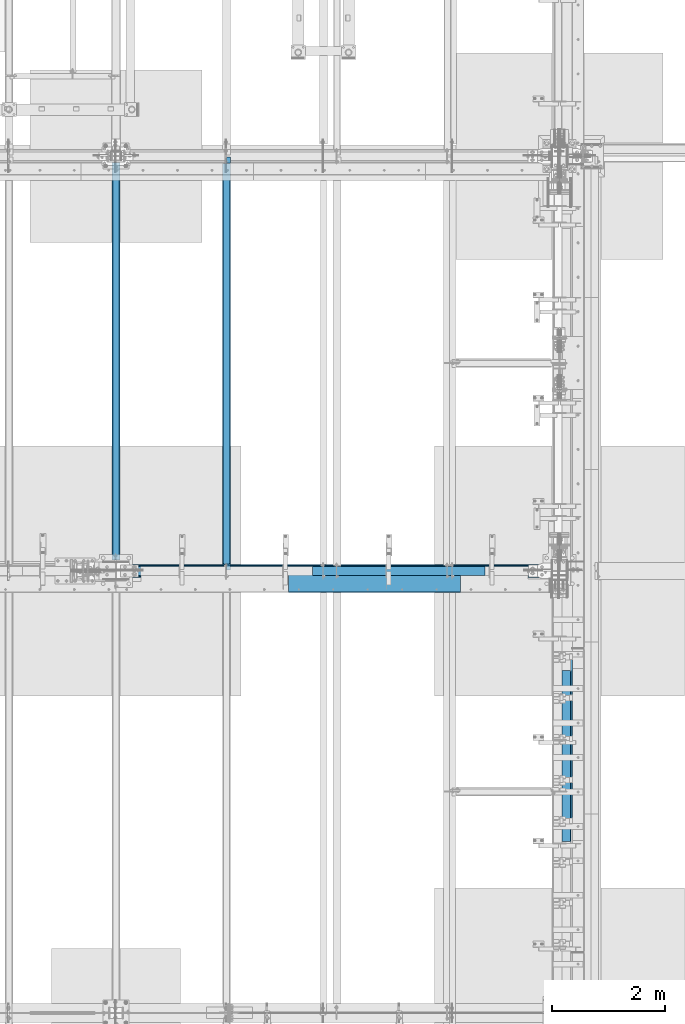
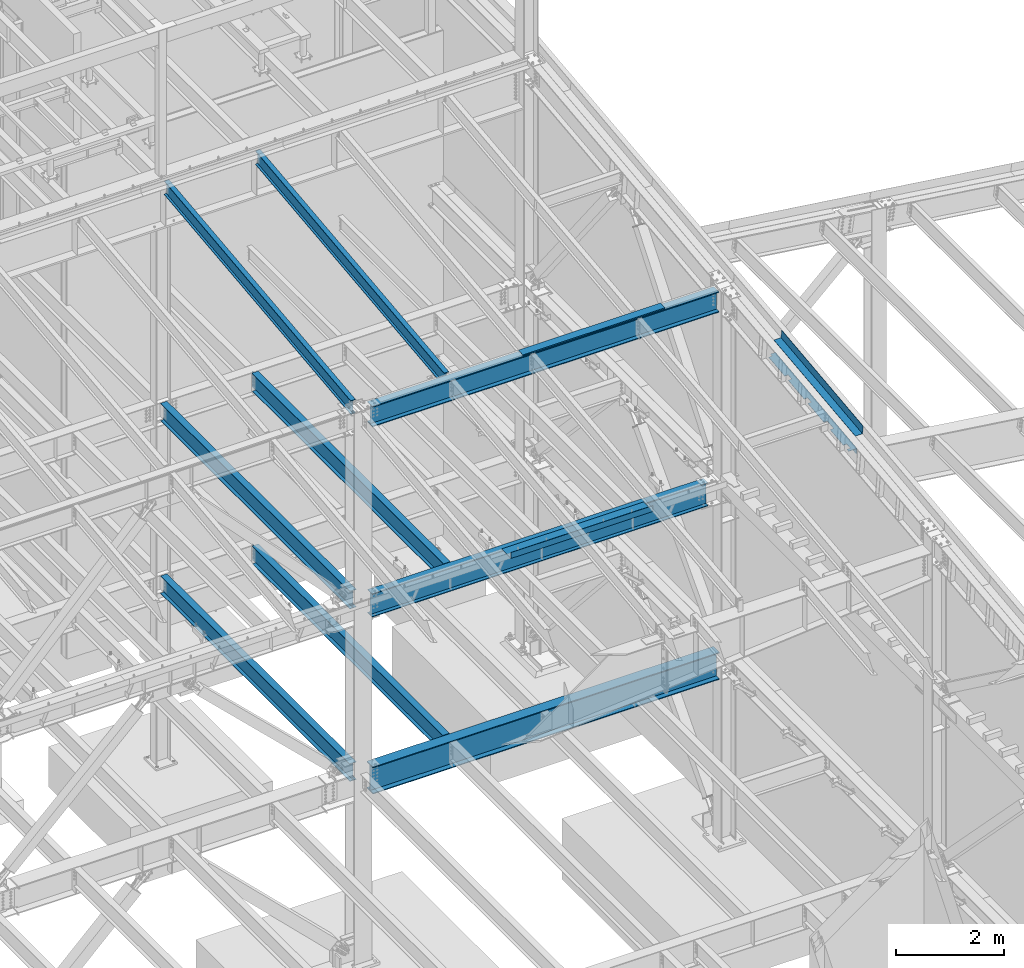
# One storey, part 739 of 1179: 13 beams, 10 elements without a shape of their own.
"""IFC2X3 building model written with IfcOpenShell, lengths in millimetres."""

from ifc_helpers import new_model, si_unit, frame, origin_with_axes, place, context, subcontext, project, spatial, faceted_brep, material, type_object, element, aggregate, save


model = new_model("IFC2X3")

# Units and contexts
model_context = context("Model", 3, precision=1e-05, world=origin_with_axes())
body_context = subcontext(model_context, "Body", "Model", "MODEL_VIEW")
ifc_project = project(units=[si_unit("LENGTHUNIT", "METRE", prefix="MILLI"), si_unit("AREAUNIT", "SQUARE_METRE"), si_unit("VOLUMEUNIT", "CUBIC_METRE"), si_unit("MASSUNIT", "GRAM", prefix="KILO"), si_unit("TIMEUNIT", "SECOND"), si_unit("PLANEANGLEUNIT", "RADIAN"), si_unit("SOLIDANGLEUNIT", "STERADIAN"), si_unit("THERMODYNAMICTEMPERATUREUNIT", "DEGREE_CELSIUS"), si_unit("LUMINOUSINTENSITYUNIT", "LUMEN")], contexts=[model_context])

# Site, building, storey
site_placement = place(None, origin_with_axes())
site = spatial("IfcSite", under=ifc_project, at=site_placement, CompositionType="ELEMENT")
building_placement = place(site_placement, origin_with_axes())
building = spatial("IfcBuilding", under=site, at=building_placement, Name="Undefined", CompositionType="ELEMENT")
storey_placement = place(building_placement, origin_with_axes())
storey = spatial("IfcBuildingStorey", under=building, at=storey_placement, Name="Undefined", CompositionType="ELEMENT", Elevation=0.0)

# Assembly, beam
assembly_1_placement = place(storey_placement, origin_with_axes())
assembly_1 = element("IfcElementAssembly", 1, at=assembly_1_placement, inside=storey, Name="BEAM", AssemblyPlace="NOTDEFINED", PredefinedType="RIGID_FRAME")
ifc_material_1 = material(Name="STEEL/A36")
beam_type_1 = type_object("IfcBeamType", PredefinedType="NOTDEFINED")
beam_1_placement = place(assembly_1_placement, frame((21463.0000078249, 27124.0249999701, 12269.3906249899), z_axis=(-1.0, 0.0, 0.0), x_axis=(0.0, 0.0, 1.0)))
beam_1 = element("IfcBeam", 2, at=beam_1_placement, type_object=beam_type_1, material=ifc_material_1, Name="BENT_PLATE", context=body_context, shape_type="Brep", body=[
    faceted_brep([(-2.91038304567337e-11, -4.76250000000073, -1524.0), (-2.91038304567337e-11, -4.76250000000073, 1524.0), (2.91038304567337e-11, 4.76250000000073, 1524.0), (2.91038304567337e-11, 4.76250000000073, -1524.0), (43.0065173285329, 4.76249999974607, 1524.0), (43.0065173285329, 4.76249999974607, -1524.0), (32.344586885798, -4.7625000001899, -1524.0), (32.344586885798, -4.7625000001899, 1524.0), (25.4267482213236, -150.812499999749, 1524.0), (25.4267482213236, -150.812499999749, -1524.0), (16.9174425672263, -141.287499999748, -1524.0), (16.9174425672263, -141.287499999748, 1524.0), (8.54161044117063e-08, -150.812499999749, 1524.0), (8.54161044117063e-08, -150.812499999749, -1524.0), (8.54161044117063e-08, -141.287499999748, 1524.0), (8.54161044117063e-08, -141.287499999748, -1524.0)], [[[0, 1, 2, 3]], [[3, 2, 4, 5]], [[1, 0, 6, 7]], [[5, 4, 8, 9]], [[7, 6, 10, 11]], [[9, 8, 12, 13]], [[8, 4, 2, 1, 7, 11, 14, 12]], [[11, 10, 15, 14]], [[10, 6, 0, 3, 5, 9, 13, 15]], [[14, 15, 13, 12]]]),
])

assembly_2_placement = place(storey_placement, origin_with_axes())
assembly_2 = element("IfcElementAssembly", 3, at=assembly_2_placement, inside=storey, Name="BEAM", AssemblyPlace="NOTDEFINED", PredefinedType="RIGID_FRAME")
ifc_material_2 = material(Name="STEEL/A992")
beam_type_2 = type_object("IfcBeamType", Name="W16X31", PredefinedType="NOTDEFINED")
beam_2_placement = place(assembly_2_placement, frame((18415.0, 27051.0, 7812.0875), z_axis=(0.0, 0.0, 1.0), x_axis=(0.0, 1.0, 0.0)))
beam_2 = element("IfcBeam", 4, at=beam_2_placement, type_object=beam_type_2, material=ifc_material_2, Name="BEAM", ObjectType="W16X31", context=body_context, shape_type="Brep", body=[
    faceted_brep([(82.5499999999993, -3.17500000000291, 166.6875), (82.5499999999993, 3.17500000000291, 166.6875), (17.4624999999942, 3.17499999999927, 166.6875), (17.4624999999942, -3.17499999999927, 166.6875), (87.4100797087813, -3.17499999999927, 167.654229922588), (87.4100797087813, 3.17497144083973, 167.654229922588), (91.5302561769349, -3.17499999999927, 170.407243823066), (91.5302561769349, 3.17496966460385, 170.407243823066), (94.2832700774125, -3.17499999999927, 174.52742029122), (94.2832700774125, 3.1749670062818, 174.52742029122), (95.25, -3.17499999999927, 179.387499809265), (95.25, 3.1749638705769, 179.387499809265), (95.25, -69.8499999999985, 201.6125), (95.25, 69.8499999999985, 201.6125), (95.25, 69.8499999999985, 190.5), (95.25, 3.17499999999927, 190.5), (95.25, -3.17499999999927, 190.5), (95.25, -69.8499999999985, 190.5), (7196.1375, 3.17499999999927, -190.5), (7196.1375, 69.8500000000004, -190.5), (144.462499999994, 69.8499999999985, -190.5), (144.462499999994, 3.17549991607666, -190.5), (17.4624999999942, -3.17499999999927, -190.5), (17.4624999999942, -69.8499999999985, -190.5), (7323.1375, -69.8500000000004, -190.5), (7323.1375, -3.17499999999927, -190.5), (17.4624999999942, -69.8499999999985, -201.6125), (7323.1375, -69.8500000000004, -201.6125), (7196.1375, 69.8500000000004, -201.6125), (7196.1375, 3.17549991607484, -201.6125), (7323.1375, 3.17549991607484, -201.6125), (17.4624999999942, 3.17549991607666, -201.6125), (144.462499999994, 3.17549991607666, -201.6125), (144.462499999994, 69.8499999999985, -201.6125), (17.4624999999942, 3.17499999999927, -190.5), (7323.1375, 3.17499999999927, -190.5), (7323.1375, 3.17499999999927, 166.6875), (7323.1375, -3.17499999999927, 166.6875), (7235.82499980928, 3.17499999999927, 166.6875), (7235.82499980928, -3.17499999999927, 166.6875), (7230.96492029123, 3.17499999999927, 167.654229922588), (7230.96492029123, -3.17499999999927, 167.654229922588), (7226.84474382308, 3.17499999999927, 170.407243823066), (7226.84474382308, -3.17499999999927, 170.407243823066), (7224.0917299226, 3.17499999999927, 174.52742029122), (7224.0917299226, -3.17499999999927, 174.52742029122), (7223.12500000001, 3.17499999999927, 179.387499809265), (7223.12500000001, -3.17499999999927, 179.387499809265), (7223.12500000001, -69.8500000000004, 201.6125), (7223.12500000001, -69.8500000000004, 190.5), (7223.12500000001, -3.17499999999927, 190.5), (7223.12500000001, 3.17499999999927, 190.5), (7223.12500000001, 69.8500000000004, 190.5), (7223.12500000001, 69.8500000000004, 201.6125)], [[[0, 1, 2, 3]], [[4, 5, 1, 0]], [[6, 7, 5, 4]], [[8, 9, 7, 6]], [[10, 11, 9, 8]], [[12, 13, 14, 15, 11, 10, 16, 17]], [[18, 19, 20, 21]], [[22, 23, 24, 25]], [[23, 26, 27, 24]], [[28, 29, 30, 27, 26, 31, 32, 33]], [[21, 32, 31, 34]], [[20, 33, 32, 21]], [[19, 28, 33, 20]], [[18, 29, 28, 19]], [[35, 30, 29, 18]], [[25, 24, 27, 30, 35, 36, 37]], [[37, 36, 38, 39]], [[39, 38, 40, 41]], [[41, 40, 42, 43]], [[43, 42, 44, 45]], [[45, 44, 46, 47]], [[48, 49, 50, 47, 46, 51, 52, 53]], [[49, 48, 12, 17]], [[50, 49, 17, 16]], [[8, 6, 4, 0, 3, 22, 25, 37, 39, 41, 43, 45, 47, 50, 16, 10]], [[34, 31, 26, 23, 22, 3, 2]], [[51, 46, 44, 42, 40, 38, 36, 35, 18, 21, 34, 2, 1, 5, 7, 9, 11, 15]], [[52, 51, 15, 14]], [[53, 52, 14, 13]], [[48, 53, 13, 12]]]),
])
aggregate(assembly_2, [beam_2])

assembly_3_placement = place(storey_placement, origin_with_axes())
assembly_3 = element("IfcElementAssembly", 5, at=assembly_3_placement, inside=storey, Name="BEAM", AssemblyPlace="NOTDEFINED", PredefinedType="RIGID_FRAME")
beam_3_placement = place(assembly_3_placement, frame((16459.2, 27051.0, 7812.0875), z_axis=(0.0, 0.0, 1.0), x_axis=(0.0, 1.0, 0.0)))
beam_3 = element("IfcBeam", 6, at=beam_3_placement, type_object=beam_type_2, material=ifc_material_2, Name="BEAM", ObjectType="W16X31", context=body_context, shape_type="Brep", body=[
    faceted_brep([(195.262500000001, -69.8499999999985, -201.6125), (195.262500000001, 69.8499999999985, -201.6125), (7224.7125, 69.8499999999985, -201.6125), (7224.7125, -69.8499999999985, -201.6125), (195.262500000001, -69.8499999999985, -190.5), (195.262500000001, -3.17499999999927, -190.5), (195.262500000001, -3.17499999999927, 190.5), (195.262500000001, -69.8499999999985, 190.5), (195.262500000001, -69.8499999999985, 201.6125), (195.262500000001, 69.8499999999985, 201.6125), (195.262500000001, 69.8499999999985, 190.5), (195.262500000001, 3.17499999999927, 190.5), (195.262500000001, 3.17499999999927, -190.5), (195.262500000001, 69.8499999999985, -190.5), (7224.7125, -69.8499999999985, -190.5), (7224.7125, -3.17499999999927, -190.5), (7224.7125, -3.17499999999927, 190.5), (7224.7125, -69.8499999999985, 190.5), (7224.7125, -69.8499999999985, 201.6125), (7224.7125, 69.8499999999985, 201.6125), (7224.7125, 69.8499999999985, 190.5), (7224.7125, 3.17499999999927, 190.5), (7224.7125, 3.17499999999927, 164.252489941818), (7224.7125, 3.17499999999927, -142.027503290603), (7224.7125, 3.17499999999927, -190.5), (7224.7125, 69.8499999999985, -190.5)], [[[0, 1, 2, 3]], [[0, 4, 5, 6, 7, 8, 9, 10, 11, 12, 13, 1]], [[5, 4, 14, 15]], [[6, 5, 15, 16]], [[7, 6, 16, 17]], [[8, 7, 17, 18]], [[9, 8, 18, 19]], [[10, 9, 19, 20]], [[11, 10, 20, 21]], [[12, 11, 21, 22, 23, 24]], [[13, 12, 24, 25]], [[1, 13, 25, 2]], [[24, 23, 22, 21, 20, 19, 18, 17, 16, 15, 14, 3, 2, 25]], [[4, 0, 3, 14]]]),
])
aggregate(assembly_3, [beam_3])

assembly_4_placement = place(storey_placement, origin_with_axes())
assembly_4 = element("IfcElementAssembly", 7, at=assembly_4_placement, inside=storey, Name="BEAM", AssemblyPlace="NOTDEFINED", PredefinedType="RIGID_FRAME")
beam_4_placement = place(assembly_4_placement, frame((16459.2, 27051.0, 3900.4875), z_axis=(0.0, 0.0, 1.0), x_axis=(0.0, 1.0, 0.0)))
beam_4 = element("IfcBeam", 8, at=beam_4_placement, type_object=beam_type_2, material=ifc_material_2, Name="BEAM", ObjectType="W16X31", context=body_context, shape_type="Brep", body=[
    faceted_brep([(195.371510976522, -69.8500000000004, -201.6125), (195.371510976522, 69.8500000000004, -201.6125), (7224.7125, 69.8499999999985, -201.6125), (7224.7125, -69.8499999999985, -201.6125), (195.371510976522, -69.8500000000004, -190.5), (195.371510976522, -3.17499999999927, -190.5), (195.371510976522, -3.17499999999927, 190.5), (195.371510976522, -69.8500000000004, 190.5), (195.371510976522, -69.8500000000004, 201.6125), (195.371510976522, 69.8500000000004, 201.6125), (195.371510976522, 69.8500000000004, 190.5), (195.371510976522, 3.17499999999927, 190.5), (195.371510976522, 3.17499999999927, -190.5), (195.371510976522, 69.8500000000004, -190.5), (7224.7125, -69.8499999999985, -190.5), (7224.7125, -3.17499999999927, -190.5), (7224.7125, -3.17499999999927, 190.5), (7224.7125, -69.8499999999985, 190.5), (7224.7125, -69.8499999999985, 201.6125), (7224.7125, 69.8499999999985, 201.6125), (7224.7125, 69.8499999999985, 190.5), (7224.7125, 3.17499999999927, 190.5), (7224.7125, 3.17499999999927, 164.252489941818), (7224.7125, 3.17499999999927, -142.027503290603), (7224.7125, 3.17499999999927, -190.5), (7224.7125, 69.8499999999985, -190.5)], [[[0, 1, 2, 3]], [[0, 4, 5, 6, 7, 8, 9, 10, 11, 12, 13, 1]], [[5, 4, 14, 15]], [[6, 5, 15, 16]], [[7, 6, 16, 17]], [[8, 7, 17, 18]], [[9, 8, 18, 19]], [[10, 9, 19, 20]], [[11, 10, 20, 21]], [[12, 11, 21, 22, 23, 24]], [[13, 12, 24, 25]], [[1, 13, 25, 2]], [[24, 23, 22, 21, 20, 19, 18, 17, 16, 15, 14, 3, 2, 25]], [[4, 0, 3, 14]]]),
])
aggregate(assembly_4, [beam_4])

assembly_5_placement = place(storey_placement, origin_with_axes())
assembly_5 = element("IfcElementAssembly", 9, at=assembly_5_placement, inside=storey, Name="BEAM", AssemblyPlace="NOTDEFINED", PredefinedType="RIGID_FRAME")
beam_5_placement = place(assembly_5_placement, frame((18415.0, 27051.0, 3900.4875), z_axis=(0.0, 0.0, 1.0), x_axis=(0.0, 1.0, 0.0)))
beam_5 = element("IfcBeam", 10, at=beam_5_placement, type_object=beam_type_2, material=ifc_material_2, Name="BEAM", ObjectType="W16X31", context=body_context, shape_type="Brep", body=[
    faceted_brep([(114.300000190742, -3.17499999999927, 169.8625), (114.300000190742, 3.17497080806788, 169.8625), (19.0500000762049, 3.17499999999382, 169.8625), (19.0499999238054, -3.17500000000564, 169.8625), (119.160079708789, -3.17499999999927, 170.829229922588), (119.160079708789, 3.17497018437643, 170.829229922588), (123.280256176942, -3.17499999999927, 173.582243823066), (123.280256176942, 3.1749684082497, 173.582243823066), (126.03327007742, -3.17499999999927, 177.70242029122), (126.03327007742, 3.17496575008772, 177.70242029122), (127.000000000007, -3.17499999999927, 182.562499809265), (127.000000000007, 3.174962614572, 182.562499809265), (127.000000000007, -69.8499999999985, 201.6125), (127.000000000007, 69.8499999999985, 201.6125), (127.000000000007, 69.8499999999985, 190.5), (127.000000000007, 3.17499999999927, 190.5), (127.000000000007, -3.17499999999927, 190.5), (127.000000000007, -69.8499999999985, 190.5), (7195.34375, 3.17499999999927, -190.5), (7195.34375, 69.8499999999985, -190.5), (146.049999999996, 69.8499999999985, -190.5), (146.049999999996, 3.17549991607666, -190.5), (19.0499999999993, -3.17499999999927, -190.5), (19.0499999999993, -69.8499999999985, -190.5), (7322.34375, -69.8499999999985, -190.5), (7322.34375, -3.17499999999927, -190.5), (19.0499999999993, -69.8499999999985, -201.6125), (7322.34375, -69.8499999999985, -201.6125), (7195.34375, 69.8499999999985, -201.6125), (7195.34375, 3.17549991607666, -201.6125), (7322.34375, 3.17549991607666, -201.6125), (19.0499999999993, 3.17549991607666, -201.6125), (146.049999999996, 3.17549991607666, -201.6125), (146.049999999996, 69.8499999999985, -201.6125), (19.0499999999993, 3.17499999999927, -190.5), (7322.34375, 3.17499999999927, -190.5), (7322.34375, 3.17499999999927, 169.8625), (7322.34375, -3.17499999999927, 169.8625), (7227.09374980925, 3.17499999999927, 169.8625), (7227.09374980925, -3.17499999999927, 169.8625), (7222.2336702912, 3.17499999999927, 170.829229922588), (7222.2336702912, -3.17499999999927, 170.829229922588), (7218.11349382305, 3.17499999999927, 173.582243823066), (7218.11349382305, -3.17499999999927, 173.582243823066), (7215.36047992257, 3.17499999999927, 177.70242029122), (7215.36047992257, -3.17499999999927, 177.70242029122), (7214.39374999998, 3.17499999999927, 182.562499809265), (7214.39374999998, -3.17499999999927, 182.562499809265), (7214.39374999998, -69.8499999999985, 201.6125), (7214.39374999998, -69.8499999999985, 190.5), (7214.39374999998, -3.17499999999927, 190.5), (7214.39374999998, 3.17499999999927, 190.5), (7214.39374999998, 69.8499999999985, 190.5), (7214.39374999998, 69.8499999999985, 201.6125)], [[[0, 1, 2, 3]], [[4, 5, 1, 0]], [[6, 7, 5, 4]], [[8, 9, 7, 6]], [[10, 11, 9, 8]], [[12, 13, 14, 15, 11, 10, 16, 17]], [[18, 19, 20, 21]], [[22, 23, 24, 25]], [[23, 26, 27, 24]], [[28, 29, 30, 27, 26, 31, 32, 33]], [[21, 32, 31, 34]], [[20, 33, 32, 21]], [[19, 28, 33, 20]], [[18, 29, 28, 19]], [[35, 30, 29, 18]], [[25, 24, 27, 30, 35, 36, 37]], [[37, 36, 38, 39]], [[39, 38, 40, 41]], [[41, 40, 42, 43]], [[43, 42, 44, 45]], [[45, 44, 46, 47]], [[48, 49, 50, 47, 46, 51, 52, 53]], [[49, 48, 12, 17]], [[50, 49, 17, 16]], [[8, 6, 4, 0, 3, 22, 25, 37, 39, 41, 43, 45, 47, 50, 16, 10]], [[34, 31, 26, 23, 22, 3, 2]], [[51, 46, 44, 42, 40, 38, 36, 35, 18, 21, 34, 2, 1, 5, 7, 9, 11, 15]], [[52, 51, 15, 14]], [[53, 52, 14, 13]], [[48, 53, 13, 12]]]),
])
aggregate(assembly_5, [beam_5])

assembly_6_placement = place(storey_placement, origin_with_axes())
assembly_6 = element("IfcElementAssembly", 11, at=assembly_6_placement, inside=storey, Name="BEAM", AssemblyPlace="NOTDEFINED", PredefinedType="RIGID_FRAME")
beam_type_3 = type_object("IfcBeamType", PredefinedType="NOTDEFINED")
beam_6_placement = place(assembly_6_placement, frame((24350.663, 23773.6008477538, 11936.4607052153), z_axis=(0.0, -0.993676146336441, -0.112284087038017), x_axis=(1.0, 0.0, 0.0)))
beam_6 = element("IfcBeam", 12, at=beam_6_placement, type_object=beam_type_3, material=ifc_material_1, Name="BENT_PLATE", context=body_context, shape_type="Brep", body=[
    faceted_brep([(0.0, -3.17499999999927, -1524.0), (6.00266503170133e-10, -3.17499999922438, 1524.00000000052), (6.00266503170133e-10, 3.17500000077416, 1524.00000000052), (0.0, 3.17499999999927, -1524.0), (153.987000024775, 3.17499999922438, 1524.00000000046), (153.987000022519, 3.17500000077052, -1524.00000000059), (160.337000000047, -3.17500000061591, -1523.99999999915), (160.336999999981, -3.17499999938082, 1523.99999999915), (153.987000000016, 187.325000000103, 1523.99999999907), (153.987000000016, 187.324999998867, -1523.99999999923), (160.337000000014, 187.325000000103, 1523.99999999907), (160.337000000014, 187.324999998867, -1523.99999999923)], [[[0, 1, 2, 3]], [[3, 2, 4, 5]], [[1, 0, 6, 7]], [[5, 4, 8, 9]], [[4, 2, 1, 7, 10, 8]], [[7, 6, 11, 10]], [[6, 0, 3, 5, 9, 11]], [[10, 11, 9, 8]]]),
])

assembly_7_placement = place(storey_placement, origin_with_axes())
assembly_7 = element("IfcElementAssembly", 13, at=assembly_7_placement, inside=storey, Name="BEAM", AssemblyPlace="NOTDEFINED", PredefinedType="RIGID_FRAME")
beam_type_4 = type_object("IfcBeamType", PredefinedType="NOTDEFINED")
beam_7_placement = place(assembly_7_placement, frame((21034.375, 26673.175, 8147.05000610352), z_axis=(1.0, 0.0, 0.0), x_axis=(0.0, 0.0, -1.0)))
beam_7 = element("IfcBeam", 14, at=beam_7_placement, type_object=beam_type_4, material=ifc_material_1, Name="BENT_PLATE", context=body_context, shape_type="Brep", body=[
    faceted_brep([(0.0, -3.17499999999927, -1524.0), (6.00266503170133e-10, -3.17499999922438, 1524.00000000052), (6.00266503170133e-10, 3.17500000077416, 1524.00000000052), (0.0, 3.17499999999927, -1524.0), (127.000006103516, 3.17499999999927, 1524.0), (127.000006103516, 3.17499999999927, -1524.0), (133.350006103517, -3.17499999999927, -1524.0), (133.350006103517, -3.17499999999927, 1524.0), (127.000006103516, 346.074999237058, 1524.0), (127.000006103516, 346.074999237058, -1524.0), (133.350006103517, 346.074999237058, 1524.0), (133.350006103517, 346.074999237058, -1524.0)], [[[0, 1, 2, 3]], [[3, 2, 4, 5]], [[1, 0, 6, 7]], [[5, 4, 8, 9]], [[4, 2, 1, 7, 10, 8]], [[7, 6, 11, 10]], [[6, 0, 3, 5, 9, 11]], [[10, 11, 9, 8]]]),
])

# Beam
beam_type_5 = type_object("IfcBeamType", PredefinedType="NOTDEFINED")
beam_8_placement = place(assembly_6_placement, frame((24350.662999855, 24031.5938429566, 11436.8075932318), z_axis=(0.0, -0.993676146336441, -0.112284087038017), x_axis=(1.0, 0.0, 0.0)))
beam_8 = element("IfcBeam", 15, at=beam_8_placement, type_object=beam_type_5, material=ifc_material_1, Name="BENT_PLATE", context=body_context, shape_type="Brep", body=[
    faceted_brep([(76.1995001446849, -3.09306185222886, -861.428626520152), (76.1995001446849, 3.25755176145503, -861.428626519901), (0.0, 3.17499999964821, -861.428626519904), (0.0, -3.1750000003467, -861.428626520155), (76.1995001446849, -3.09336030527447, -728.078626547343), (76.1995001446849, 3.25725330841306, -728.078626547151), (0.0, -3.17500000029395, -728.078626547343), (0.0, 3.17499999970278, -728.078626547147), (76.1995001446849, -3.09306185193418, -130.902162775223), (76.1995001446849, 3.25755176174971, -130.902162774968), (0.0, 3.1749999999447, -130.902162774975), (0.0, -3.17500000005202, -130.902162775223), (76.1995001446849, -3.0933603049798, 2.44783719758561), (76.1995001446849, 3.25725330870591, 2.44783719778206), (0.0, -3.17499999999745, 2.44783719758561), (0.0, 3.17499999999927, 2.44783719778206), (0.0, -3.17499999975371, 604.38559409455), (0.0, 3.17500000024302, 604.385594098156), (76.1995001446849, -3.09306172911056, 604.38559409455), (76.1995001446849, 3.25755188457515, 604.385594098152), (76.1995001446849, -3.09395970339028, 835.669732782706), (76.1995001446849, 3.25665391028997, 835.669732786253), (0.0, -3.17499999966094, 835.669732782706), (0.0, 3.17500000033579, 835.669732786253), (0.0, -3.17499999945903, 1330.15076471213), (0.0, 3.17500000053587, 1330.15076471238), (76.1995001446849, -3.09306185134665, 1330.15076471213), (76.1995001446849, 3.25755176233906, 1330.15076471238), (76.1995001446849, -3.09336030439408, 1463.50076468493), (76.1995001446849, 3.25725330929163, 1463.50076468513), (0.0, -3.17499999940446, 1463.50076468493), (0.0, 3.17500000058862, 1463.50076468513), (6.00266503170133e-10, -3.17499999922438, 1524.00000000052), (6.00266503170133e-10, 3.17500000077416, 1524.00000000052), (185.737000000001, 3.17499999999927, 1524.0), (179.387000000001, -3.17499999999927, 1524.0), (179.38700020294, -136.524999792508, 1523.99999999976), (185.737000202938, -136.524999792508, 1523.99999999976), (185.737000000001, 3.17499999999927, -1524.0), (185.737000202247, -136.524999793119, -1523.99999999991), (179.387000202249, -136.524999793119, -1523.99999999991), (179.387000000001, -3.17499999999927, -1524.0), (76.1995001437463, -3.17500000061955, -1523.99999999915), (76.1995001437463, 3.17499999937536, -1523.99999999915), (76.1995001447249, -3.09395384627533, -1458.60628646512), (76.1995001447249, 3.2566597674595, -1458.60628646265), (0.0, -3.17500000058862, -1458.60628646512), (0.0, 3.17499999940628, -1458.60628646265)], [[[0, 1, 2, 3]], [[4, 5, 1, 0]], [[6, 7, 5, 4]], [[8, 9, 10, 11]], [[12, 13, 9, 8]], [[14, 15, 13, 12]], [[16, 17, 15, 14]], [[18, 19, 17, 16]], [[20, 21, 19, 18]], [[22, 23, 21, 20]], [[24, 25, 23, 22]], [[26, 27, 25, 24]], [[28, 29, 27, 26]], [[30, 31, 29, 28]], [[32, 33, 31, 30]], [[34, 33, 32, 35, 36, 37]], [[38, 34, 37, 39]], [[36, 40, 39, 37]], [[35, 41, 40, 36]], [[38, 39, 40, 41, 42, 43]], [[44, 45, 43, 42]], [[46, 47, 45, 44]], [[47, 46, 3, 2]], [[10, 9, 13, 15, 17, 19, 21, 23, 25, 27, 29, 31, 33, 34, 38, 43, 45, 47, 2, 1, 5, 7]], [[11, 10, 7, 6]], [[3, 46, 44, 42, 41, 35, 32, 30, 28, 26, 24, 22, 20, 18, 16, 14, 12, 8, 11, 6, 4, 0]]]),
])

aggregate(assembly_6, [beam_8, beam_6])

beam_type_6 = type_object("IfcBeamType", Name="W18X65", PredefinedType="NOTDEFINED")
beam_9_placement = place(assembly_1_placement, frame((16459.2, 27050.9999999701, 12036.0281250357), z_axis=(0.0, 0.0, 1.0), x_axis=(1.0, 0.0, 0.0)))
beam_9 = element("IfcBeam", 16, at=beam_9_placement, type_object=beam_type_6, material=ifc_material_2, Name="BEAM", ObjectType="W18X65", context=body_context, shape_type="Brep", body=[
    faceted_brep([(247.650000000016, -96.8375000000015, -233.362499999999), (247.650000000016, 96.8375000000015, -233.362499999999), (7678.73749918356, 96.8375000000015, -233.362499999999), (7678.73749918356, -96.8375000000015, -233.362499999999), (247.650000000016, -96.8375000000015, -214.3125), (247.650000000016, -5.55625000000146, -214.3125), (247.650000000016, -5.55625000000146, 214.3125), (247.650000000016, -96.8375000000015, 214.3125), (247.650000000016, -96.8375000000015, 233.362499999999), (247.650000000016, 96.8375000000015, 233.362499999999), (247.650000000016, 96.8375000000015, 214.3125), (247.650000000016, 5.55625000000146, 214.3125), (247.650000000016, 5.55625000000146, 196.00250000013), (247.650000000016, 5.55625000000146, -110.277499999971), (247.650000000016, 5.55625000000146, -214.3125), (247.650000000016, 96.8375000000015, -214.3125), (7678.73749918356, -96.8375000000015, -214.3125), (7678.73749918356, -5.55625000000146, -214.3125), (7678.73749918356, -5.55625000000146, 214.3125), (7678.73749918356, -96.8375000000015, 214.3125), (7678.73749918356, -96.8375000000015, 233.362499999999), (7678.73749918356, 96.8375000000015, 233.362499999999), (7678.73749918356, 96.8375000000015, 214.3125), (7678.73749918356, 5.55625000000146, 214.3125), (7678.73749918356, 5.55625000000146, -214.3125), (7678.73749918356, 96.8375000000015, -214.3125)], [[[0, 1, 2, 3]], [[0, 4, 5, 6, 7, 8, 9, 10, 11, 12, 13, 14, 15, 1]], [[5, 4, 16, 17]], [[6, 5, 17, 18]], [[7, 6, 18, 19]], [[8, 7, 19, 20]], [[9, 8, 20, 21]], [[10, 9, 21, 22]], [[11, 10, 22, 23]], [[14, 13, 12, 11, 23, 24]], [[15, 14, 24, 25]], [[1, 15, 25, 2]], [[24, 23, 22, 21, 20, 19, 18, 17, 16, 3, 2, 25]], [[4, 0, 3, 16]]]),
])

aggregate(assembly_1, [beam_1, beam_9])

# Assembly, beam
assembly_8_placement = place(storey_placement, origin_with_axes())
assembly_8 = element("IfcElementAssembly", 17, at=assembly_8_placement, inside=storey, Name="BEAM", AssemblyPlace="NOTDEFINED", PredefinedType="RIGID_FRAME")
beam_type_7 = type_object("IfcBeamType", Name="W12X22", PredefinedType="NOTDEFINED")
beam_10_placement = place(assembly_8_placement, frame((18415.0, 27068.4779321143, 12149.0171463666), z_axis=(0.0, -0.112284087038017, 0.993676146336441), x_axis=(0.0, 0.993676146336441, 0.112284087038017)))
beam_10 = element("IfcBeam", 18, at=beam_10_placement, type_object=beam_type_7, material=ifc_material_2, Name="BEAM", ObjectType="W12X22", context=body_context, shape_type="Brep", body=[
    faceted_brep([(-15.5407998117698, -3.17499999999927, -144.462499999911), (-16.7964975778959, -3.17487472700668, -155.574999999904), (135.603493906594, -3.17489667232439, -155.574999999968), (135.603493906547, -3.17499999999927, -144.462499999972), (135.603487048622, -50.7999999999993, -144.462499999972), (135.603487048618, -50.7999999999993, -155.574999999964), (7139.32426989316, 3.17499999999927, -144.462500002814), (7139.32426989316, 50.7999999999993, -144.462500002814), (135.603501703274, 50.7999999999993, -144.462499999974), (135.603494845222, 3.17489668907729, -144.462500001895), (135.603494845269, 3.17510329651486, -155.574999999966), (-16.7964975778959, 3.17512524196718, -155.574999999904), (-15.5407998117698, 3.17499999999927, -144.462499999911), (135.603501703274, 50.7999999999993, -155.574999999966), (7138.06857212703, 50.7999999999993, -155.575000002807), (7142.71544233383, 3.17499999999927, -114.451772291532), (7168.54976507951, 3.17499999999927, 114.173235457372), (7171.97241181248, 3.17499999999927, 144.462499997011), (7171.97241181248, 50.7999999999993, 144.462499997011), (7173.22810957861, 50.7999999999993, 155.574999997003), (7173.22810957861, -50.7999999999993, 155.574999997003), (7171.97241181248, -50.7999999999993, 144.462499997011), (7171.97241181248, -3.17499999999927, 144.462499997011), (7139.32426989316, -3.17499999999927, -144.462500002814), (7139.32426989316, -50.7999999999993, -144.462500002814), (7138.06857212703, -50.7999999999993, -155.575000002807), (-14.7372101429282, -3.17499999999927, -137.351003558748), (10.2521606948103, -3.17499999999927, 83.7964659398294), (10.2521606948103, 3.17499999999927, 83.7964659398294), (-14.7371967980653, 3.17499999999927, -137.350885461223), (92.2801267643408, -3.17499999999927, 74.5274145334315), (92.2801267643408, 3.17499999999927, 74.5274145334315), (97.2180202374875, -3.17499999999927, 74.9423214058406), (97.2180202374875, 3.17499999999927, 74.9423214058406), (101.621260964999, -3.17499999999927, 77.215295396114), (101.621260964999, 3.17499999999927, 77.215295396114), (104.819495461597, -3.17499999999927, 81.0002968187928), (104.819495461597, 3.17499999999927, 81.0002968187928), (106.325821517235, -3.17499999999927, 85.7210935183975), (106.325821517235, 3.17499999999927, 85.7210935183975), (112.963522565431, 3.17499999999927, 144.462499999876), (112.963522565431, 50.7999999999993, 144.462499999876), (114.219220331557, 50.7999999999993, 155.57499999987), (114.219220331557, -50.7999999999993, 155.57499999987), (112.963522565431, -50.7999999999993, 144.462499999876), (112.963522565431, -3.17499999999927, 144.462499999876)], [[[0, 1, 2, 3]], [[4, 3, 2, 5]], [[6, 7, 8, 9]], [[9, 10, 11, 12]], [[8, 13, 10, 9]], [[7, 14, 13, 8]], [[6, 15, 16, 17, 18, 19, 20, 21, 22, 23, 24, 25, 14, 7]], [[25, 24, 4, 5]], [[1, 11, 10, 13, 14, 25, 5, 2]], [[26, 27, 28, 29, 12, 11, 1, 0]], [[30, 31, 28, 27]], [[32, 33, 31, 30]], [[34, 35, 33, 32]], [[36, 37, 35, 34]], [[38, 39, 37, 36]], [[17, 16, 15, 6, 9, 12, 29, 28, 31, 33, 35, 37, 39, 40]], [[18, 17, 40, 41]], [[19, 18, 41, 42]], [[20, 19, 42, 43]], [[21, 20, 43, 44]], [[22, 21, 44, 45]], [[43, 42, 41, 40, 39, 38, 45, 44]], [[36, 34, 32, 30, 27, 26, 0, 3, 23, 22, 45, 38]], [[24, 23, 3, 4]]]),
])
aggregate(assembly_8, [beam_10])

assembly_9_placement = place(storey_placement, origin_with_axes())
assembly_9 = element("IfcElementAssembly", 19, at=assembly_9_placement, inside=storey, Name="BEAM", AssemblyPlace="NOTDEFINED", PredefinedType="RIGID_FRAME")
beam_11_placement = place(assembly_9_placement, frame((16459.2, 27068.4779321143, 12149.0171463666), z_axis=(0.0, -0.112284087038017, 0.993676146336441), x_axis=(0.0, 0.993676146336441, 0.112284087038017)))
beam_11 = element("IfcBeam", 20, at=beam_11_placement, type_object=beam_type_7, material=ifc_material_2, Name="BEAM", ObjectType="W12X22", context=body_context, shape_type="Brep", body=[
    faceted_brep([(161.336237803036, -50.7999999999993, -155.574999999977), (161.336237803036, 50.7999999999993, -155.574999999977), (7138.06857212703, 50.7999999999993, -155.575000002807), (7138.06857212703, -50.7999999999993, -155.575000002807), (162.591935569162, -50.7999999999993, -144.462499999983), (162.591935569162, -3.17499999999927, -144.462499999983), (195.240077488488, -3.17499999999927, 144.462499999841), (195.240077488488, -50.7999999999993, 144.462499999841), (196.495775254614, -50.7999999999993, 155.574999999833), (196.495775254614, 50.7999999999993, 155.574999999833), (195.240077488488, 50.7999999999993, 144.462499999841), (195.240077488488, 3.17499999999927, 144.462499999841), (162.591935569162, 3.17499999999927, -144.462499999983), (162.591935569162, 50.7999999999993, -144.462499999983), (7139.32426989316, -50.7999999999993, -144.462500002814), (7139.32426989316, -3.17499999999927, -144.462500002814), (7171.97241181248, -3.17499999999927, 144.462499997011), (7171.97241181248, -50.7999999999993, 144.462499997011), (7173.22810957861, -50.7999999999993, 155.574999997003), (7173.22810957861, 50.7999999999993, 155.574999997003), (7171.97241181248, 50.7999999999993, 144.462499997011), (7171.97241181248, 3.17499999999927, 144.462499997011), (7168.54976507951, 3.17499999999927, 114.173235457372), (7142.71544233383, 3.17499999999927, -114.451772291532), (7139.32426989316, 3.17499999999927, -144.462500002814), (7139.32426989316, 50.7999999999993, -144.462500002814)], [[[0, 1, 2, 3]], [[0, 4, 5, 6, 7, 8, 9, 10, 11, 12, 13, 1]], [[5, 4, 14, 15]], [[6, 5, 15, 16]], [[7, 6, 16, 17]], [[8, 7, 17, 18]], [[9, 8, 18, 19]], [[10, 9, 19, 20]], [[11, 10, 20, 21]], [[12, 11, 21, 22, 23, 24]], [[13, 12, 24, 25]], [[1, 13, 25, 2]], [[24, 23, 22, 21, 20, 19, 18, 17, 16, 15, 14, 3, 2, 25]], [[4, 0, 3, 14]]]),
])
aggregate(assembly_9, [beam_11])

# Beam
beam_type_8 = type_object("IfcBeamType", Name="W21X57", PredefinedType="NOTDEFINED")
beam_12_placement = place(assembly_7_placement, frame((16459.2, 27051.0, 7747.0), z_axis=(0.0, 0.0, 1.0), x_axis=(1.0, 0.0, 0.0)))
beam_12 = element("IfcBeam", 21, at=beam_12_placement, type_object=beam_type_8, material=ifc_material_2, Name="BEAM", ObjectType="W21X57", context=body_context, shape_type="Brep", body=[
    faceted_brep([(247.650000000001, 82.5499999999993, -266.7), (247.650000000001, 82.5499999999993, -250.825), (7450.13749918357, 82.5499999999993, -250.825), (7450.13749918357, 82.5499999999993, -266.7), (247.650000000001, 4.76250000000073, -250.825), (7450.13749918357, 4.76250000000073, -250.825), (247.650000000001, 4.76250000000073, 250.825), (7450.13749918357, 4.76250000000073, 250.825), (247.650000000001, 82.5499999999993, 250.825), (7450.13749918357, 82.5499999999993, 250.825), (247.650000000001, 82.5499999999993, 266.7), (7450.13749918357, 82.5499999999993, 266.7), (247.650000000001, -82.5499999999993, 266.7), (7450.13749918357, -82.5499999999993, 266.7), (247.650000000001, -82.5499999999993, 250.825), (7450.13749918357, -82.5499999999993, 250.825), (247.650000000001, -4.76250000000073, 250.825), (7450.13749918357, -4.76250000000073, 250.825), (247.650000000001, -4.76250000000073, -250.825), (7450.13749918357, -4.76250000000073, -250.825), (247.650000000001, -82.5499999999993, -250.825), (7450.13749918357, -82.5499999999993, -250.825), (247.650000000001, -82.5499999999993, -266.7), (7450.13749918357, -82.5499999999993, -266.7)], [[[0, 1, 2, 3]], [[1, 4, 5, 2]], [[4, 6, 7, 5]], [[6, 8, 9, 7]], [[8, 10, 11, 9]], [[10, 12, 13, 11]], [[12, 14, 15, 13]], [[14, 16, 17, 15]], [[16, 18, 19, 17]], [[18, 20, 21, 19]], [[20, 22, 23, 21]], [[22, 0, 3, 23]], [[5, 7, 9, 11, 13, 15, 17, 19, 21, 23, 3, 2]], [[22, 20, 18, 16, 14, 12, 10, 8, 6, 4, 1, 0]]]),
])

aggregate(assembly_7, [beam_7, beam_12])

# Assembly, beam
assembly_10_placement = place(storey_placement, origin_with_axes())
assembly_10 = element("IfcElementAssembly", 22, at=assembly_10_placement, inside=storey, Name="BEAM", AssemblyPlace="NOTDEFINED", PredefinedType="RIGID_FRAME")
beam_type_9 = type_object("IfcBeamType", Name="W24X84", PredefinedType="NOTDEFINED")
beam_13_placement = place(assembly_10_placement, frame((16459.2, 27051.0, 3795.7125), z_axis=(0.0, 0.0, 1.0), x_axis=(1.0, 0.0, 0.0)))
beam_13 = element("IfcBeam", 23, at=beam_13_placement, type_object=beam_type_9, material=ifc_material_2, Name="BEAM", ObjectType="W24X84", context=body_context, shape_type="Brep", body=[
    faceted_brep([(247.649999999998, -114.299999999999, -306.3875), (247.649999999998, 114.299999999999, -306.3875), (7678.73749918356, 114.299999999999, -306.3875), (7678.73749918356, -114.299999999999, -306.3875), (247.649999999998, -114.299999999999, -287.3375), (247.649999999998, -6.34999999999854, -287.3375), (247.649999999998, -6.34999999999854, 287.3375), (247.649999999998, -114.299999999999, 287.3375), (247.649999999998, -114.299999999999, 306.3875), (247.649999999998, 114.299999999999, 306.3875), (247.649999999998, 114.299999999999, 287.3375), (247.649999999998, 6.34999999999854, 287.3375), (247.649999999998, 6.34999999999854, 243.6275), (247.649999999998, 6.34999999999854, -215.052499999999), (247.649999999998, 6.34999999999854, -287.3375), (247.649999999998, 114.299999999999, -287.3375), (7678.73749918356, -114.299999999999, -287.3375), (7678.73749918356, -6.34999999999854, -287.3375), (7678.73749918356, -6.34999999999854, 287.3375), (7678.73749918356, -114.299999999999, 287.3375), (7678.73749918356, -114.299999999999, 306.3875), (7678.73749918356, 114.299999999999, 306.3875), (7678.73749918356, 114.299999999999, 287.3375), (7678.73749918356, 6.34999999999854, 287.3375), (7678.73749918356, 6.34999999999854, -287.3375), (7678.73749918356, 114.299999999999, -287.3375)], [[[0, 1, 2, 3]], [[0, 4, 5, 6, 7, 8, 9, 10, 11, 12, 13, 14, 15, 1]], [[5, 4, 16, 17]], [[6, 5, 17, 18]], [[7, 6, 18, 19]], [[8, 7, 19, 20]], [[9, 8, 20, 21]], [[10, 9, 21, 22]], [[11, 10, 22, 23]], [[14, 13, 12, 11, 23, 24]], [[15, 14, 24, 25]], [[1, 15, 25, 2]], [[24, 23, 22, 21, 20, 19, 18, 17, 16, 3, 2, 25]], [[4, 0, 3, 16]]]),
])
aggregate(assembly_10, [beam_13])

save(model, "model.ifc")
